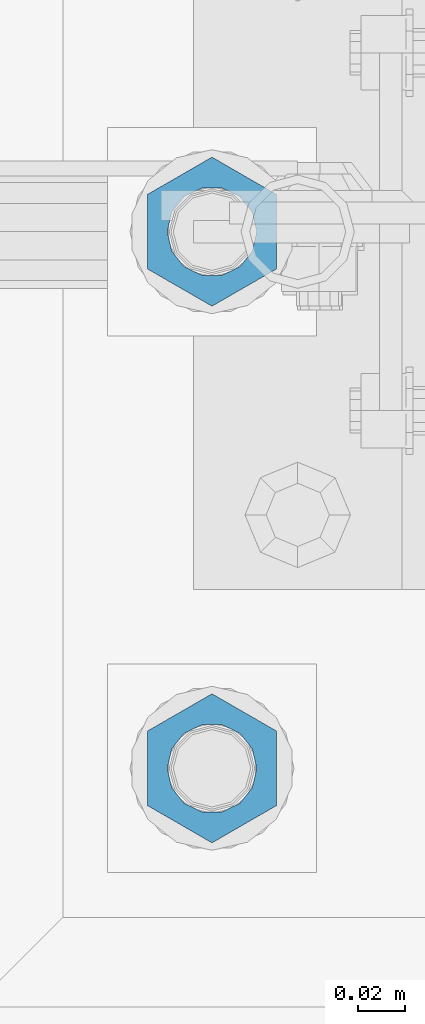
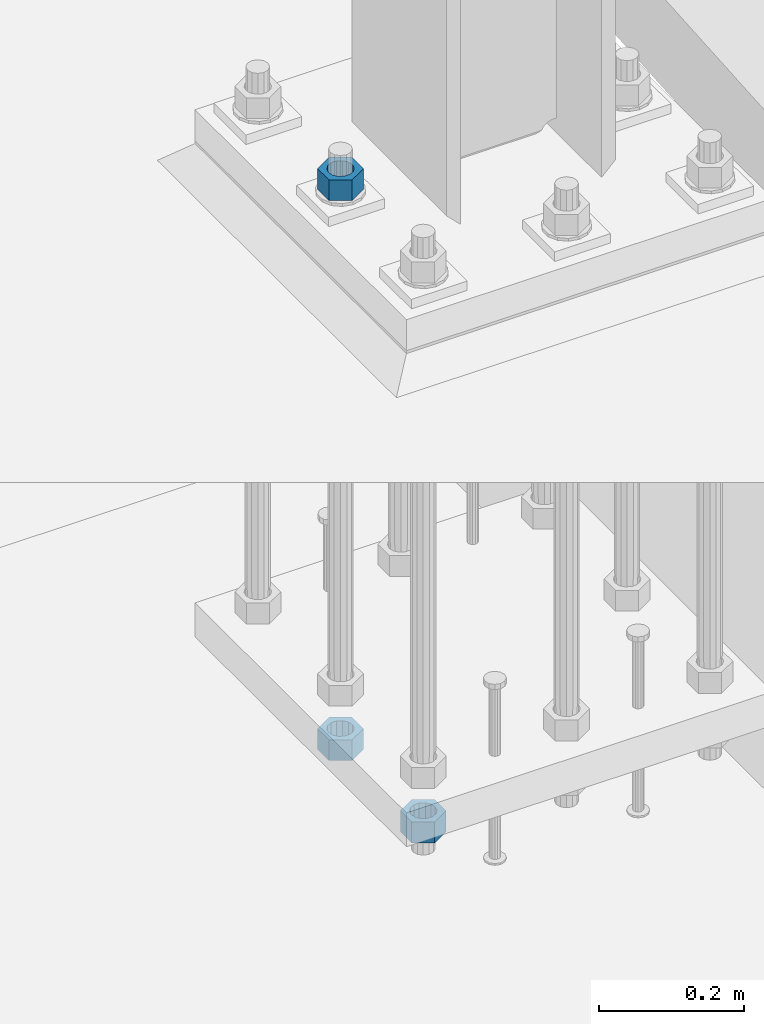
# One storey, part 1387 of 1876: 3 beams, 1 element without a shape of its own.
"""IFC2X3 building model written with IfcOpenShell, lengths in millimetres."""

import ifcopenshell
import ifcopenshell.guid

model = None  # the IFC model being written
_history = None  # IfcOwnerHistory: only IFC2X3 demands one
_inside = {}  # id of a spatial element -> (the spatial element, [elements in it])
_under = {}  # id of a project, library or spatial element -> (it, [spatial elements below it])
_declared = {}  # id of a project -> (the project, [libraries it declares])
_typed = {}  # id of a type object -> (the type object, [elements of that type])
_made_of = {}  # id of a material, layer set ... -> (it, [elements and type objects made of it])


def new_model(schema):
    """Start an empty IFC model of exactly this schema.

    Asked for "IFC4X3", IfcOpenShell would pick the latest addendum, in which some entities
    have other attributes; the version numbers below select the first issue.
    IFC2X3 requires an IfcOwnerHistory on every rooted entity: one is made here for all.
    """
    global model, _history
    if schema == "IFC4X3":
        model = ifcopenshell.file(schema_version=(4, 3, 0, 0))
    else:
        model = ifcopenshell.file(schema=schema)
    _inside.clear()
    _under.clear()
    _declared.clear()
    _typed.clear()
    _made_of.clear()
    _history = None
    if model.schema == "IFC2X3":
        org = make("IfcOrganization", Name="unknown")
        user = make(
            "IfcPersonAndOrganization",
            ThePerson=make("IfcPerson", FamilyName="unknown"),
            TheOrganization=org,
        )
        app = make(
            "IfcApplication",
            ApplicationDeveloper=org,
            Version="unknown",
            ApplicationFullName="unknown",
            ApplicationIdentifier="unknown",
        )
        _history = make(
            "IfcOwnerHistory",
            OwningUser=user,
            OwningApplication=app,
            ChangeAction="ADDED",
            CreationDate=0,
        )
    return model


def make(cls, **values):
    """One entity of the class cls with the attributes given. An attribute that is None is left unset."""
    return model.create_entity(
        cls, **{name: value for name, value in values.items() if value is not None}
    )


def rooted(cls, **values):
    """An entity with a GlobalId (a new one), such as an element, a storey or a relation."""
    return make(cls, GlobalId=ifcopenshell.guid.new(), OwnerHistory=_history, **values)


def si_unit(unit_type, name, prefix=None):
    """IfcSIUnit, for example si_unit("LENGTHUNIT", "METRE", prefix="MILLI")."""
    return make("IfcSIUnit", UnitType=unit_type, Prefix=prefix, Name=name)


def assignment(units):
    """IfcUnitAssignment: the units of a project."""
    return None if units is None else make("IfcUnitAssignment", Units=units)


def point(xyz):
    """IfcCartesianPoint."""
    return None if xyz is None else make("IfcCartesianPoint", Coordinates=xyz)


def direction(xyz):
    """IfcDirection."""
    return None if xyz is None else make("IfcDirection", DirectionRatios=xyz)


def frame(location, z_axis=None, x_axis=None):
    """IfcAxis2Placement3D, a coordinate frame: its origin and axes. An axis left out is left unset."""
    return make(
        "IfcAxis2Placement3D",
        Location=point(location),
        Axis=direction(z_axis),
        RefDirection=direction(x_axis),
    )


def origin_with_axes():
    """The frame at (0, 0, 0) with the z axis (0, 0, 1) and the x axis (1, 0, 0) written out."""
    return frame((0.0, 0.0, 0.0), z_axis=(0.0, 0.0, 1.0), x_axis=(1.0, 0.0, 0.0))


def place(relative_to, where):
    """IfcLocalPlacement: puts the frame where relative to a parent placement (None: the world)."""
    return make(
        "IfcLocalPlacement", PlacementRelTo=relative_to, RelativePlacement=where
    )


def context(
    kind, dimensions, precision=None, world=None, true_north=None, identifier=None
):
    """IfcGeometricRepresentationContext, for example the 3D "Model" context."""
    return make(
        "IfcGeometricRepresentationContext",
        ContextIdentifier=identifier,
        ContextType=kind,
        CoordinateSpaceDimension=dimensions,
        Precision=precision,
        WorldCoordinateSystem=world,
        TrueNorth=true_north,
    )


def subcontext(parent, identifier, kind, view, scale=None):
    """IfcGeometricRepresentationSubContext, for example "Body" below "Model"."""
    return make(
        "IfcGeometricRepresentationSubContext",
        ContextIdentifier=identifier,
        ContextType=kind,
        ParentContext=parent,
        TargetScale=scale,
        TargetView=view,
    )


def project(units=None, contexts=None):
    """IfcProject with its units and contexts."""
    return rooted(
        "IfcProject",
        Name="project",
        RepresentationContexts=contexts,
        UnitsInContext=assignment(units),
    )


def spatial(cls, under=None, at=None, **own):
    """A site, building, storey or space (cls), placed at a placement, below another one or the project."""
    s = rooted(cls, ObjectPlacement=at, **own)
    if under is not None:
        _under.setdefault(under.id(), (under, []))[1].append(s)
    return s


def faces_of(points, faces, orient=None, outer=None):
    """IfcFace entities. A face is a list of loops; a loop is a list of indices into points, from 0.

    orient and outer hold one flag for each loop. By default every Orientation is true, the
    first loop of a face is its IfcFaceOuterBound and the others are IfcFaceBound.
    """
    made = []
    for i, loops in enumerate(faces):
        bounds = []
        for j, loop in enumerate(loops):
            is_outer = j == 0 if outer is None else outer[i][j]
            bounds.append(
                make(
                    "IfcFaceOuterBound" if is_outer else "IfcFaceBound",
                    Bound=make("IfcPolyLoop", Polygon=[points[k] for k in loop]),
                    Orientation=True if orient is None else orient[i][j],
                )
            )
        made.append(make("IfcFace", Bounds=bounds))
    return made


def faceted_brep(points, faces, orient=None, outer=None, voids=None):
    """IfcFacetedBrep: a solid bounded by flat faces; with voids (closed shells), ...WithVoids."""
    shared = [point(p) for p in points]
    hull = make("IfcClosedShell", CfsFaces=faces_of(shared, faces, orient, outer))
    if voids is None:
        return make("IfcFacetedBrep", Outer=hull)
    return make(
        "IfcFacetedBrepWithVoids",
        Outer=hull,
        Voids=[
            make(cls, CfsFaces=faces_of(shared, fs, o, b)) for cls, fs, o, b in voids
        ],
    )


def shape(context_of_items, identifier, shape_type, items):
    """IfcShapeRepresentation: the items that make up one representation, for example the "Body"."""
    return make(
        "IfcShapeRepresentation",
        ContextOfItems=context_of_items,
        RepresentationIdentifier=identifier,
        RepresentationType=shape_type,
        Items=items,
    )


def material(Name=None, Category=None):
    """IfcMaterial."""
    return make("IfcMaterial", Name=Name, Category=Category)


def made_of(thing, what):
    """Note that an element or type object is made of a material, layer set ...; save() writes the relation."""
    if what is not None:
        _made_of.setdefault(what.id(), (what, []))[1].append(thing)
    return thing


def type_object(cls, material=None, **own):
    """A type object (cls), such as IfcWallType, which elements share."""
    return made_of(rooted(cls, **own), material)


def element(
    cls,
    number,
    at=None,
    inside=None,
    cuts=None,
    type_object=None,
    material=None,
    context=None,
    identifier="Body",
    shape_type=None,
    held_by="IfcProductDefinitionShape",
    body=None,
    shapes=None,
    **own,
):
    """One element of the class cls, such as IfcWall. Its Tag is "e" and its number.

    at: its placement. inside: the storey or other place that contains it. cuts: it is an
    opening in that element (IfcRelVoidsElement). A single representation is given by context,
    identifier, shape_type and body (its items); several are given by shapes. held_by: the class
    of the entity that holds the representations. save() writes the other relations.
    """
    e = rooted(cls, Tag="e%d" % number, ObjectPlacement=at, **own)
    if body is not None:
        shapes = [shape(context, identifier, shape_type, body)]
    if shapes is not None:
        e.Representation = make(held_by, Representations=shapes)
    if inside is not None:
        _inside.setdefault(inside.id(), (inside, []))[1].append(e)
    if cuts is not None:
        rooted(
            "IfcRelVoidsElement", RelatingBuildingElement=cuts, RelatedOpeningElement=e
        )
    if type_object is not None:
        _typed.setdefault(type_object.id(), (type_object, []))[1].append(e)
    return made_of(e, material)


def aggregate(whole, parts):
    """IfcRelAggregates: a whole, such as a stair, and the parts it consists of."""
    return rooted("IfcRelAggregates", RelatingObject=whole, RelatedObjects=parts)


def save(model, path):
    """Write the relations noted so far, then the file.

    IfcRelAggregates (storeys below a building ...), IfcRelContainedInSpatialStructure (elements
    in a storey), IfcRelDefinesByType, IfcRelAssociatesMaterial and IfcRelDeclares: one each for
    every whole, place, type object, material and project.
    """
    for whole, parts in _under.values():
        aggregate(whole, parts)
    for where, things in _inside.values():
        rooted(
            "IfcRelContainedInSpatialStructure",
            RelatedElements=things,
            RelatingStructure=where,
        )
    for kind, things in _typed.values():
        rooted("IfcRelDefinesByType", RelatedObjects=things, RelatingType=kind)
    for what, things in _made_of.values():
        rooted("IfcRelAssociatesMaterial", RelatedObjects=things, RelatingMaterial=what)
    for by, libraries in _declared.values():
        rooted("IfcRelDeclares", RelatingContext=by, RelatedDefinitions=libraries)
    model.write(path)


model = new_model("IFC2X3")

# Units and contexts
model_context = context("Model", 3, precision=1e-05, world=origin_with_axes())
body_context = subcontext(model_context, "Body", "Model", "MODEL_VIEW")
ifc_project = project(units=[si_unit("LENGTHUNIT", "METRE", prefix="MILLI"), si_unit("AREAUNIT", "SQUARE_METRE"), si_unit("VOLUMEUNIT", "CUBIC_METRE"), si_unit("MASSUNIT", "GRAM", prefix="KILO"), si_unit("TIMEUNIT", "SECOND"), si_unit("PLANEANGLEUNIT", "RADIAN"), si_unit("SOLIDANGLEUNIT", "STERADIAN"), si_unit("THERMODYNAMICTEMPERATUREUNIT", "DEGREE_CELSIUS"), si_unit("LUMINOUSINTENSITYUNIT", "LUMEN")], contexts=[model_context])

# Site, building, storey
site_placement = place(None, origin_with_axes())
site = spatial("IfcSite", under=ifc_project, at=site_placement, CompositionType="ELEMENT")
building_placement = place(site_placement, origin_with_axes())
building = spatial("IfcBuilding", under=site, at=building_placement, Name="Undefined", CompositionType="ELEMENT")
storey_placement = place(building_placement, origin_with_axes())
storey = spatial("IfcBuildingStorey", under=building, at=storey_placement, Name="Undefined", CompositionType="ELEMENT", Elevation=0.0)

# Assembly, beams
assembly_placement = place(storey_placement, origin_with_axes())
assembly = element("IfcElementAssembly", 1, at=assembly_placement, inside=storey, Name="TEMPLATE", AssemblyPlace="NOTDEFINED", PredefinedType="RIGID_FRAME")
ifc_material = material(Name="STEEL/A563")
beam_type = type_object("IfcBeamType", Name="1-3/8_HEAVY_HEX_NUT", PredefinedType="NOTDEFINED")
beam_1_placement = place(assembly_placement, frame((7391.4, -7340.6, -793.75), z_axis=(1.0, 0.0, 0.0), x_axis=(0.0, 0.0, -1.0)))
beam_1 = element("IfcBeam", 2, at=beam_1_placement, type_object=beam_type, material=ifc_material, Name="NUT", ObjectType="1-3/8_HEAVY_HEX_NUT", context=body_context, shape_type="Brep", body=[
    faceted_brep([(0.0, -31.75, 0.0), (0.0, -15.8800001144409, -27.5), (34.925, -15.8800001144409, -27.5), (34.925, -31.75, 0.0), (0.0, 15.8800001144409, -27.5), (34.925, 15.8800001144409, -27.5), (0.0, 31.75, 0.0), (34.925, 31.75, 0.0), (0.0, 15.8800001144409, 27.5), (34.925, 15.8800001144409, 27.5), (0.0, -15.8800001144409, 27.5), (34.925, -15.8800001144409, 27.5), (0.0, 0.0, 19.0499999999993), (0.0, 8.2654848991624, 17.1634562461559), (34.925, 8.26548489916252, 17.163456246155), (34.925, 0.0, 19.0499992370605), (0.0, 14.8938891445259, 11.8774802497237), (34.925, 14.8938891445259, 11.8774802497246), (0.0, 18.5723759832526, 4.2390236220981), (34.925, 18.5723759832528, 4.23902362209628), (0.0, 18.5723759832526, -4.2390236220981), (34.925, 18.5723759832528, -4.23902362209628), (0.0, 14.8938891445259, -11.8774802497237), (34.925, 14.8938891445259, -11.8774802497246), (0.0, 8.2654848991624, -17.1634562461568), (34.925, 8.26548489916252, -17.163456246155), (0.0, 0.0, -19.05), (34.925, 0.0, -19.0499992370605), (0.0, -8.2654848991624, -17.1634562461559), (34.925, -8.26548489916252, -17.163456246155), (0.0, -14.8938891445259, -11.8774802497237), (34.925, -14.8938891445259, -11.8774802497246), (0.0, -18.5723759832526, -4.2390236220981), (34.925, -18.5723759832528, -4.23902362209628), (0.0, -18.5723759832526, 4.2390236220981), (34.925, -18.5723759832528, 4.23902362209628), (0.0, -14.8938891445259, 11.8774802497237), (34.925, -14.8938891445259, 11.8774802497246), (0.0, -8.2654848991624, 17.1634562461568), (34.925, -8.26548489916252, 17.163456246155)], [[[0, 1, 2, 3]], [[1, 4, 5, 2]], [[4, 6, 7, 5]], [[6, 8, 9, 7]], [[8, 10, 11, 9]], [[10, 0, 3, 11]], [[12, 13, 14, 15]], [[13, 16, 17, 14]], [[16, 18, 19, 17]], [[18, 20, 21, 19]], [[20, 22, 23, 21]], [[22, 24, 25, 23]], [[24, 26, 27, 25]], [[26, 28, 29, 27]], [[28, 30, 31, 29]], [[30, 32, 33, 31]], [[32, 34, 35, 33]], [[34, 36, 37, 35]], [[36, 38, 39, 37]], [[38, 12, 15, 39]], [[5, 7, 9, 11, 3, 2], [17, 19, 21, 23, 25, 27, 29, 31, 33, 35, 37, 39, 15, 14]], [[10, 8, 6, 4, 1, 0], [38, 36, 34, 32, 30, 28, 26, 24, 22, 20, 18, 16, 13, 12]]]),
])
beam_2_placement = place(assembly_placement, frame((7391.4, -7112.0, 150.8125), z_axis=(1.0, 0.0, 0.0), x_axis=(0.0, 0.0, -1.0)))
beam_2 = element("IfcBeam", 3, at=beam_2_placement, type_object=beam_type, material=ifc_material, Name="NUT", ObjectType="1-3/8_HEAVY_HEX_NUT", context=body_context, shape_type="Brep", body=[
    faceted_brep([(0.0, -31.75, 0.0), (0.0, -15.8800001144409, -27.5), (34.925, -15.8800001144409, -27.5), (34.925, -31.75, 0.0), (0.0, 15.8800001144409, -27.5), (34.925, 15.8800001144409, -27.5), (0.0, 31.75, 0.0), (34.925, 31.75, 0.0), (0.0, 15.8800001144409, 27.5), (34.925, 15.8800001144409, 27.5), (0.0, -15.8800001144409, 27.5), (34.925, -15.8800001144409, 27.5), (0.0, 0.0, 19.0499999999993), (0.0, 8.2654848991624, 17.1634562461559), (34.925, 8.26548489916252, 17.163456246155), (34.925, 0.0, 19.0499992370605), (0.0, 14.8938891445259, 11.8774802497237), (34.925, 14.8938891445259, 11.8774802497246), (0.0, 18.5723759832526, 4.2390236220981), (34.925, 18.5723759832528, 4.23902362209628), (0.0, 18.5723759832526, -4.2390236220981), (34.925, 18.5723759832528, -4.23902362209628), (0.0, 14.8938891445259, -11.8774802497237), (34.925, 14.8938891445259, -11.8774802497246), (0.0, 8.2654848991624, -17.1634562461568), (34.925, 8.26548489916252, -17.163456246155), (0.0, 0.0, -19.05), (34.925, 0.0, -19.0499992370605), (0.0, -8.2654848991624, -17.1634562461559), (34.925, -8.26548489916252, -17.163456246155), (0.0, -14.8938891445259, -11.8774802497237), (34.925, -14.8938891445259, -11.8774802497246), (0.0, -18.5723759832526, -4.2390236220981), (34.925, -18.5723759832528, -4.23902362209628), (0.0, -18.5723759832526, 4.2390236220981), (34.925, -18.5723759832528, 4.23902362209628), (0.0, -14.8938891445259, 11.8774802497237), (34.925, -14.8938891445259, 11.8774802497246), (0.0, -8.2654848991624, 17.1634562461568), (34.925, -8.26548489916252, 17.163456246155)], [[[0, 1, 2, 3]], [[1, 4, 5, 2]], [[4, 6, 7, 5]], [[6, 8, 9, 7]], [[8, 10, 11, 9]], [[10, 0, 3, 11]], [[12, 13, 14, 15]], [[13, 16, 17, 14]], [[16, 18, 19, 17]], [[18, 20, 21, 19]], [[20, 22, 23, 21]], [[22, 24, 25, 23]], [[24, 26, 27, 25]], [[26, 28, 29, 27]], [[28, 30, 31, 29]], [[30, 32, 33, 31]], [[32, 34, 35, 33]], [[34, 36, 37, 35]], [[36, 38, 39, 37]], [[38, 12, 15, 39]], [[5, 7, 9, 11, 3, 2], [17, 19, 21, 23, 25, 27, 29, 31, 33, 35, 37, 39, 15, 14]], [[10, 8, 6, 4, 1, 0], [38, 36, 34, 32, 30, 28, 26, 24, 22, 20, 18, 16, 13, 12]]]),
])
beam_3_placement = place(assembly_placement, frame((7391.4, -7112.0, -793.75), z_axis=(1.0, 0.0, 0.0), x_axis=(0.0, 0.0, -1.0)))
beam_3 = element("IfcBeam", 4, at=beam_3_placement, type_object=beam_type, material=ifc_material, Name="NUT", ObjectType="1-3/8_HEAVY_HEX_NUT", context=body_context, shape_type="Brep", body=[
    faceted_brep([(0.0, -31.75, 0.0), (0.0, -15.8800001144409, -27.5), (34.925, -15.8800001144409, -27.5), (34.925, -31.75, 0.0), (0.0, 15.8800001144409, -27.5), (34.925, 15.8800001144409, -27.5), (0.0, 31.75, 0.0), (34.925, 31.75, 0.0), (0.0, 15.8800001144409, 27.5), (34.925, 15.8800001144409, 27.5), (0.0, -15.8800001144409, 27.5), (34.925, -15.8800001144409, 27.5), (0.0, 0.0, 19.0499999999993), (0.0, 8.2654848991624, 17.1634562461559), (34.925, 8.26548489916252, 17.163456246155), (34.925, 0.0, 19.0499992370605), (0.0, 14.8938891445259, 11.8774802497237), (34.925, 14.8938891445259, 11.8774802497246), (0.0, 18.5723759832526, 4.2390236220981), (34.925, 18.5723759832528, 4.23902362209628), (0.0, 18.5723759832526, -4.2390236220981), (34.925, 18.5723759832528, -4.23902362209628), (0.0, 14.8938891445259, -11.8774802497237), (34.925, 14.8938891445259, -11.8774802497246), (0.0, 8.2654848991624, -17.1634562461568), (34.925, 8.26548489916252, -17.163456246155), (0.0, 0.0, -19.05), (34.925, 0.0, -19.0499992370605), (0.0, -8.2654848991624, -17.1634562461559), (34.925, -8.26548489916252, -17.163456246155), (0.0, -14.8938891445259, -11.8774802497237), (34.925, -14.8938891445259, -11.8774802497246), (0.0, -18.5723759832526, -4.2390236220981), (34.925, -18.5723759832528, -4.23902362209628), (0.0, -18.5723759832526, 4.2390236220981), (34.925, -18.5723759832528, 4.23902362209628), (0.0, -14.8938891445259, 11.8774802497237), (34.925, -14.8938891445259, 11.8774802497246), (0.0, -8.2654848991624, 17.1634562461568), (34.925, -8.26548489916252, 17.163456246155)], [[[0, 1, 2, 3]], [[1, 4, 5, 2]], [[4, 6, 7, 5]], [[6, 8, 9, 7]], [[8, 10, 11, 9]], [[10, 0, 3, 11]], [[12, 13, 14, 15]], [[13, 16, 17, 14]], [[16, 18, 19, 17]], [[18, 20, 21, 19]], [[20, 22, 23, 21]], [[22, 24, 25, 23]], [[24, 26, 27, 25]], [[26, 28, 29, 27]], [[28, 30, 31, 29]], [[30, 32, 33, 31]], [[32, 34, 35, 33]], [[34, 36, 37, 35]], [[36, 38, 39, 37]], [[38, 12, 15, 39]], [[5, 7, 9, 11, 3, 2], [17, 19, 21, 23, 25, 27, 29, 31, 33, 35, 37, 39, 15, 14]], [[10, 8, 6, 4, 1, 0], [38, 36, 34, 32, 30, 28, 26, 24, 22, 20, 18, 16, 13, 12]]]),
])
aggregate(assembly, [beam_1, beam_2, beam_3])

save(model, "model.ifc")
